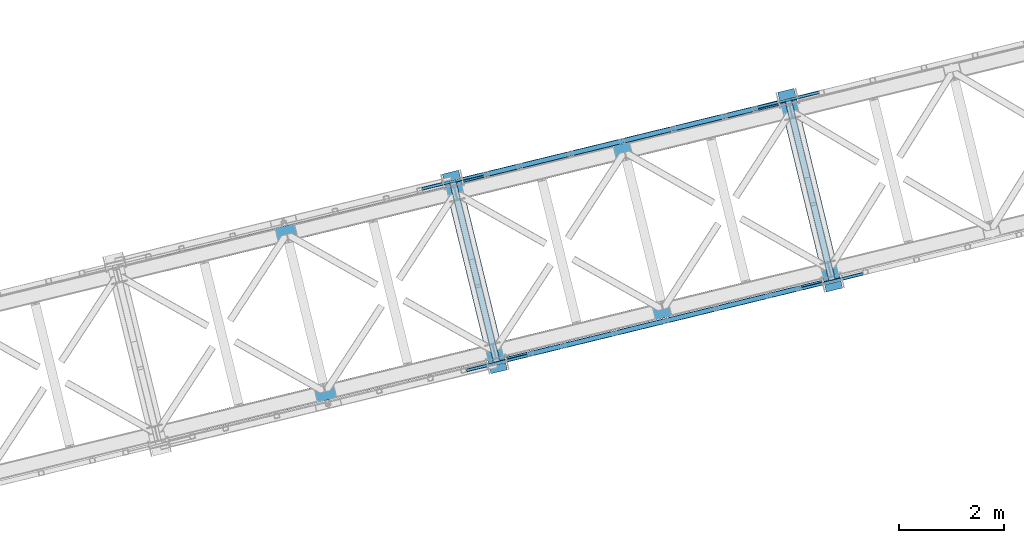
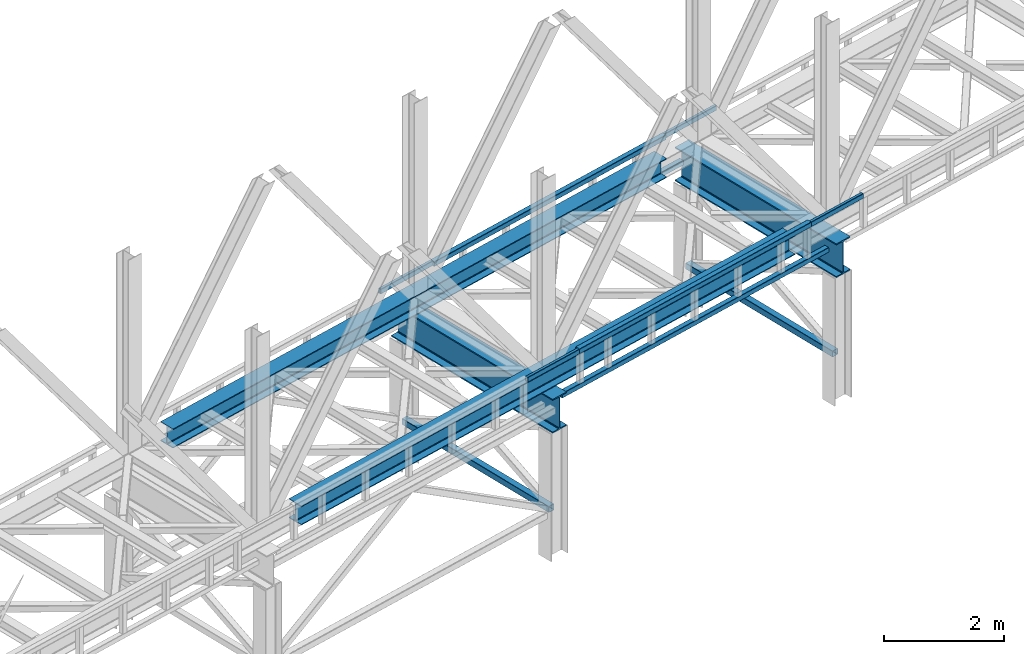
# One storey, part 17 of 93: 12 beams, 2 members.
"""IFC4 building model written with IfcOpenShell, lengths in millimetres."""

from ifc_helpers import new_model, entity, si_unit, converted_unit, derived_unit, direction, frame, origin, place, context, subcontext, project, spatial, indexed_curve, outline, extrude, material, type_object, element, save


model = new_model("IFC4")

# Units and contexts
model_context = context("Model", 3, precision=0.01, world=origin(), true_north=direction((6.12303176911189e-17, 1.0)))
plan_context = context("Plan", 3, precision=0.01, world=origin(), true_north=direction((6.12303176911189e-17, 1.0)))
body_context = subcontext(model_context, "Body", "Model", "MODEL_VIEW")
ifc_project = project(units=[si_unit("LENGTHUNIT", "METRE", prefix="MILLI"), si_unit("AREAUNIT", "SQUARE_METRE"), si_unit("VOLUMEUNIT", "CUBIC_METRE"), converted_unit("PLANEANGLEUNIT", "DEGREE", entity("IfcRatioMeasure", 0.0174532925199433), si_unit("PLANEANGLEUNIT", "RADIAN"), dimensions=[0, 0, 0, 0, 0, 0, 0]), si_unit("MASSUNIT", "GRAM", prefix="KILO"), derived_unit("MASSDENSITYUNIT", [(si_unit("MASSUNIT", "GRAM", prefix="KILO"), 1), (si_unit("LENGTHUNIT", "METRE"), -3)]), derived_unit("MOMENTOFINERTIAUNIT", [(si_unit("LENGTHUNIT", "METRE"), 4)]), si_unit("TIMEUNIT", "SECOND"), si_unit("FREQUENCYUNIT", "HERTZ"), si_unit("THERMODYNAMICTEMPERATUREUNIT", "DEGREE_CELSIUS"), derived_unit("THERMALTRANSMITTANCEUNIT", [(si_unit("MASSUNIT", "GRAM", prefix="KILO"), 1), (si_unit("THERMODYNAMICTEMPERATUREUNIT", "KELVIN"), -1), (si_unit("TIMEUNIT", "SECOND"), -3)]), derived_unit("VOLUMETRICFLOWRATEUNIT", [(si_unit("LENGTHUNIT", "METRE"), 3), (si_unit("TIMEUNIT", "SECOND"), -1)]), derived_unit("MASSFLOWRATEUNIT", [(si_unit("MASSUNIT", "GRAM", prefix="KILO"), 1), (si_unit("TIMEUNIT", "SECOND"), -1)]), derived_unit("ROTATIONALFREQUENCYUNIT", [(si_unit("TIMEUNIT", "SECOND"), -1)]), si_unit("ELECTRICCURRENTUNIT", "AMPERE"), si_unit("ELECTRICVOLTAGEUNIT", "VOLT"), si_unit("POWERUNIT", "WATT"), si_unit("FORCEUNIT", "NEWTON", prefix="KILO"), si_unit("ILLUMINANCEUNIT", "LUX"), si_unit("LUMINOUSFLUXUNIT", "LUMEN"), si_unit("LUMINOUSINTENSITYUNIT", "CANDELA"), derived_unit("USERDEFINED", [(si_unit("MASSUNIT", "GRAM", prefix="KILO"), -1), (si_unit("LENGTHUNIT", "METRE"), -2), (si_unit("TIMEUNIT", "SECOND"), 3), (si_unit("LUMINOUSFLUXUNIT", "LUMEN"), 1)]), derived_unit("LINEARVELOCITYUNIT", [(si_unit("LENGTHUNIT", "METRE"), 1), (si_unit("TIMEUNIT", "SECOND"), -1)]), si_unit("PRESSUREUNIT", "PASCAL"), derived_unit("USERDEFINED", [(si_unit("LENGTHUNIT", "METRE"), -2), (si_unit("MASSUNIT", "GRAM", prefix="KILO"), 1), (si_unit("TIMEUNIT", "SECOND"), -2)]), derived_unit("LINEARFORCEUNIT", [(si_unit("MASSUNIT", "GRAM", prefix="KILO"), 1), (si_unit("LENGTHUNIT", "METRE"), 1), (si_unit("TIMEUNIT", "SECOND"), -2), (si_unit("LENGTHUNIT", "METRE"), -1)]), derived_unit("PLANARFORCEUNIT", [(si_unit("MASSUNIT", "GRAM", prefix="KILO"), 1), (si_unit("LENGTHUNIT", "METRE"), 1), (si_unit("TIMEUNIT", "SECOND"), -2), (si_unit("LENGTHUNIT", "METRE"), -2)])], contexts=[model_context, plan_context])

# Site, building, storey
site_placement = place(None, origin())
site = spatial("IfcSite", under=ifc_project, at=site_placement, CompositionType="ELEMENT")
building_placement = place(site_placement, origin())
building = spatial("IfcBuilding", under=site, at=building_placement, CompositionType="ELEMENT")
storey_placement = place(building_placement, frame((0.0, 0.0, 15900.0)))
storey = spatial("IfcBuildingStorey", under=building, at=storey_placement, CompositionType="ELEMENT", Elevation=15900.0)

# Beams
ifc_material = material(Name="Metal painted (White)")
beam_type = type_object("IfcBeamType", PredefinedType="BEAM")
beam_1_placement = place(storey_placement, origin())
element("IfcBeam", 1, at=beam_1_placement, inside=storey, type_object=beam_type, material=ifc_material, ObjectType="Steel Beam", PredefinedType="BEAM", context=body_context, shape_type="SweptSolid", body=[
    extrude(outline(indexed_curve([(-345.500000000002, -159.999999999997), (-322.5, -159.999999999997), (-322.5, -37.4999999999995), (-320.216385975338, -26.019497029052), (-313.713203435595, -16.2867965644011), (-303.980502970953, -9.78361402465815), (-292.499999999998, -7.49999999999633), (292.500000000001, -7.49999999999633), (303.980502970953, -9.78361402465815), (313.713203435597, -16.2867965644011), (320.21638597534, -26.019497029052), (322.5, -37.4999999999995), (322.5, -159.999999999997), (345.499999999997, -159.999999999997), (345.499999999997, 159.999999999997), (322.5, 159.999999999997), (322.5, 37.4999999999995), (320.21638597534, 26.019497029052), (313.713203435597, 16.2867965644011), (303.980502970953, 9.78361402465815), (292.500000000001, 7.50000000000079), (-292.499999999998, 7.50000000000526), (-303.98050297095, 9.78361402466262), (-313.713203435591, 16.2867965644011), (-320.216385975338, 26.0194970290475), (-322.5, 37.4999999999995), (-322.5, 160.000000000002), (-345.500000000002, 159.999999999997), (-345.500000000002, -159.999999999997)], self_intersect=False)), frame((-35697.8015074168, 8488.14785129996, 2947.5), z_axis=(-0.236826092990338, 0.971552058141473, 0.0), x_axis=(0.0, 0.0, 1.0)), (0.0, 0.0, 1.0), 3899.99999999999),
])
beam_2_placement = place(storey_placement, origin())
element("IfcBeam", 2, at=beam_2_placement, inside=storey, type_object=beam_type, material=ifc_material, ObjectType="Steel Beam", PredefinedType="BEAM", context=body_context, shape_type="SweptSolid", body=[
    extrude(outline(indexed_curve([(-345.500000000002, -159.999999999992), (-322.5, -159.999999999992), (-322.5, -37.4999999999948), (-320.216385975338, -26.0194970290473), (-313.713203435595, -16.2867965643967), (-303.980502970953, -9.78361402465343), (-292.499999999998, -7.49999999999633), (292.500000000001, -7.49999999999633), (303.980502970953, -9.78361402465343), (313.713203435597, -16.2867965643967), (320.21638597534, -26.0194970290473), (322.5, -37.4999999999948), (322.5, -159.999999999992), (345.499999999997, -159.999999999992), (345.499999999997, 160.000000000006), (322.5, 160.000000000006), (322.5, 37.5000000000037), (320.21638597534, 26.0194970290562), (313.713203435597, 16.2867965644056), (303.980502970953, 9.78361402466287), (292.500000000001, 7.50000000000526), (-292.499999999998, 7.50000000000526), (-303.98050297095, 9.78361402466708), (-313.713203435591, 16.2867965644014), (-320.216385975338, 26.019497029052), (-322.5, 37.5000000000037), (-322.5, 160.000000000001), (-345.500000000002, 160.000000000006), (-345.500000000002, -159.999999999992)], self_intersect=False)), frame((-29334.1355265902, 10039.3587603867, 2947.5), z_axis=(-0.23682609299033, 0.971552058141475, 0.0), x_axis=(0.0, 0.0, 1.0)), (0.0, 0.0, 1.0), 3899.99999999999),
])
beam_3_placement = place(storey_placement, origin())
element("IfcBeam", 3, at=beam_3_placement, inside=storey, type_object=beam_type, material=ifc_material, ObjectType="Steel Beam", PredefinedType="BEAM", context=body_context, shape_type="SweptSolid", body=[
    extrude(outline(indexed_curve([(-195.999999999999, -150.000000000003), (-179.999999999996, -150.000000000003), (-179.999999999996, -27.7500000000041), (-178.325349715245, -19.3309644879692), (-173.556349186101, -12.1936508138986), (-166.419035512029, -7.42465028475491), (-157.999999999997, -5.7500000000032), (158.000000000005, -5.7500000000032), (166.419035512033, -7.42465028475491), (173.556349186107, -12.1936508138986), (178.325349715251, -19.3309644879692), (180.0, -27.7500000000041), (180.0, -150.000000000003), (196.000000000005, -150.000000000003), (196.000000000005, 149.999999999998), (180.0, 149.999999999998), (180.0, 27.7499999999978), (178.325349715251, 19.330964487965), (173.556349186107, 12.1936508138923), (166.419035512033, 7.42465028474965), (158.000000000005, 5.74999999999584), (-157.999999999997, 5.74999999999584), (-166.419035512029, 7.42465028474965), (-173.556349186101, 12.1936508138933), (-178.325349715245, 19.330964487965), (-179.999999999996, 27.7499999999978), (-179.999999999996, 150.0), (-195.999999999999, 149.999999999998), (-195.999999999999, -150.000000000003)], self_intersect=False)), frame((-41354.6674774729, 7520.93929218686, 3489.0), z_axis=(0.971552058141476, 0.236826092990324, 0.0), x_axis=(0.0, 0.0, 1.0)), (0.0, 0.0, 1.0), 11400.0),
])
beam_4_placement = place(storey_placement, origin())
element("IfcBeam", 4, at=beam_4_placement, inside=storey, type_object=beam_type, material=ifc_material, ObjectType="Steel Beam", PredefinedType="BEAM", context=body_context, shape_type="SweptSolid", body=[
    extrude(outline(indexed_curve([(-195.999999999999, -150.000000000002), (-179.999999999996, -150.000000000002), (-179.999999999996, -27.750000000002), (-178.325349715245, -19.3309644879681), (-173.556349186101, -12.1936508138975), (-166.419035512029, -7.42465028475491), (-157.999999999997, -5.75000000000215), (158.000000000005, -5.75000000000215), (166.419035512033, -7.42465028475491), (173.556349186107, -12.1936508138975), (178.325349715251, -19.3309644879681), (180.0, -27.750000000002), (180.0, -150.000000000002), (196.000000000005, -150.000000000002), (196.000000000005, 149.999999999998), (180.0, 149.999999999998), (180.0, 27.7499999999978), (178.325349715251, 19.330964487966), (173.556349186107, 12.1936508138933), (166.419035512033, 7.4246502847507), (158.000000000005, 5.74999999999794), (-157.999999999997, 5.74999999999794), (-166.419035512029, 7.4246502847486), (-173.556349186101, 12.1936508138912), (-178.325349715247, 19.330964487966), (-179.999999999996, 27.7499999999957), (-179.999999999996, 149.999999999998), (-195.999999999999, 149.999999999998), (-195.999999999999, -150.000000000002)], self_intersect=False)), frame((-42088.828365743, 10532.7506724254, 3489.0), z_axis=(0.971552058141477, 0.236826092990322, 0.0), x_axis=(0.0, 0.0, 1.0)), (0.0, 0.0, 1.0), 11400.0),
])
beam_5_placement = place(storey_placement, origin())
element("IfcBeam", 5, at=beam_5_placement, inside=storey, type_object=beam_type, material=ifc_material, ObjectType="Steel Beam", PredefinedType="BEAM", context=body_context, shape_type="SweptSolid", body=[
    extrude(outline(indexed_curve([(29.4768951152948, -56.8428769008151), (33.3787015556177, -56.8428769008151), (36.9835006656516, -55.3497202198128), (39.7424944584837, -52.5907264269822), (41.2356511394923, -48.9859273169492), (56.8428769008144, 29.4768951153021), (56.8428769008163, 33.3787015556236), (55.3497202198083, 36.983500665662), (52.5907264269817, 39.7424944584911), (48.9859273169474, 41.2356511394989), (-29.4768951153043, 56.8428769008214), (-33.3787015556268, 56.8428769008235), (-36.9835006656611, 55.3497202198191), (-39.7424944584921, 52.5907264269883), (-41.2356511395007, 48.9859273169553), (-56.8428769008228, -29.476895115296), (-56.8428769008247, -33.3787015556175), (-55.3497202198188, -36.9835006656555), (-52.5907264269907, -39.7424944584827), (-48.9859273169579, -41.2356511394924), (29.4768951152948, -56.8428769008151)], self_intersect=False), holes=[indexed_curve([(-50.9634988887243, -25.5484203233641), (-37.307176347567, 43.1065493048579), (-35.8140196665605, 46.7113484148914), (-33.0550258737274, 49.4703422077217), (-29.450226763691, 50.9634988887257), (-25.5484203233706, 50.963498888724), (43.106549304852, 37.3071763475664), (46.7113484148832, 35.8140196665592), (49.4703422077129, 33.0550258737295), (50.9634988887188, 29.4502267636915), (50.9634988887169, 25.54842032337), (37.3071763475586, -43.1065493048518), (35.81401966655, -46.7113484148849), (33.0550258737224, -49.4703422077141), (29.4502267636851, -50.9634988887179), (25.5484203233636, -50.963498888716), (-43.1065493048565, -37.3071763475567), (-46.7113484148907, -35.8140196665489), (-49.4703422077195, -33.0550258737194), (-50.9634988887242, -29.450226763686), (-50.9634988887243, -25.5484203233641)], self_intersect=False)]), frame((-36379.7476398528, 12130.2556850215, 3118.0), z_axis=(0.971552058141621, 0.236826092989728, 0.0), x_axis=(-0.232275546019818, 0.952883957770662, 0.195090322016531)), (0.0, 0.0, 1.0), 6149.99999999998),
])
beam_6_placement = place(storey_placement, origin())
element("IfcBeam", 6, at=beam_6_placement, inside=storey, type_object=beam_type, material=ifc_material, ObjectType="Steel Beam", PredefinedType="BEAM", context=body_context, shape_type="SweptSolid", body=[
    extrude(outline(indexed_curve([(29.4768951153914, -56.8428769007589), (33.378701555713, -56.8428769007589), (36.9835006657449, -55.3497202197486), (39.742494458576, -52.590726426912), (41.2356511395787, -48.9859273168765), (56.8428769007726, 29.4768951154003), (56.8428769007651, 33.3787015557224), (55.3497202197521, 36.9835006657516), (52.5907264269217, 39.7424944585804), (48.985927316883, 41.2356511395828), (-29.4768951153921, 56.8428769007767), (-33.3787015557146, 56.8428769007724), (-36.9835006657473, 55.3497202197579), (-39.7424944585747, 52.5907264269294), (-41.2356511395774, 48.9859273168939), (-56.8428769007734, -29.4768951153824), (-56.8428769007669, -33.3787015557044), (-55.3497202197555, -36.9835006657421), (-52.5907264269213, -39.7424944585673), (-48.9859273168837, -41.235651139565), (29.4768951153914, -56.8428769007589)], self_intersect=False), holes=[indexed_curve([(-50.9634988886772, -25.5484203234418), (-37.307176347632, 43.1065493048025), (-35.8140196666283, 46.7113484148378), (-33.055025873804, 49.4703422076669), (-29.4502267637722, 50.9634988886772), (-25.5484203234488, 50.9634988886857), (43.106549304796, 37.3071763476402), (46.7113484148319, 35.8140196666341), (49.470342207663, 33.0550258738095), (50.9634988886741, 29.4502267637807), (50.9634988886805, 25.5484203234587), (37.3071763476354, -43.1065493047855), (35.8140196666347, -46.7113484148214), (33.0550258738057, -49.4703422076584), (29.4502267637739, -50.9634988886687), (25.5484203234514, -50.963498888673), (-43.1065493047935, -37.3071763476275), (-46.7113484148281, -35.814019666626), (-49.4703422076613, -33.055025873801), (-50.9634988886727, -29.4502267637633), (-50.9634988886772, -25.5484203234418)], self_intersect=False)]), frame((-35991.1268165962, 12224.9861222176, 3830.0), z_axis=(0.971552058141621, 0.236826092989728, 0.0), x_axis=(0.232275546019893, -0.952883957770972, -0.19509032201493)), (0.0, 0.0, 1.0), 5349.99999999999),
])
beam_7_placement = place(storey_placement, origin())
element("IfcBeam", 7, at=beam_7_placement, inside=storey, type_object=beam_type, material=ifc_material, ObjectType="Steel Beam", PredefinedType="BEAM", context=body_context, shape_type="SweptSolid", body=[
    extrude(outline(indexed_curve([(9.86118950714821, -52.94107046051), (13.7629959474724, -52.94107046051), (17.3677950575093, -51.4479137795159), (20.1267888503473, -48.6889199866879), (21.6199455313576, -45.0841208766564), (37.2271712928086, 33.3787015555692), (37.2271712928189, 37.2805079958903), (35.7340146118184, 40.8853071059286), (32.9750208189941, 43.6443008987626), (29.3702217089642, 45.1374575797804), (-9.86118950715112, 52.9410704605061), (-13.7629959474724, 52.94107046051), (-17.3677950575122, 51.447913779512), (-20.1267888503473, 48.6889199866879), (-21.6199455313597, 45.0841208766568), (-37.2271712928107, -33.3787015555687), (-37.2271712928189, -37.2805079958903), (-35.7340146118213, -40.8853071059325), (-32.9750208189941, -43.6443008987626), (-29.370221708965, -45.1374575797846), (9.86118950714821, -52.94107046051)], self_intersect=False), holes=[indexed_curve([(-31.3477932807058, -29.4502267636464), (-17.6914707394355, 39.204742864553), (-16.1983140584179, 42.8095419745831), (-13.439320265588, 45.5685357674083), (-9.83452115555026, 47.0616924484066), (-5.9327147152257, 47.0616924483977), (23.4908436968584, 41.2089827878538), (27.0956428068893, 39.7158261068403), (29.8546365997166, 36.9568323140057), (31.3477932807141, 33.3520332039679), (31.3477932807058, 29.4502267636464), (17.6914707394355, -39.204742864553), (16.1983140584221, -42.8095419745839), (13.4393202655851, -45.5685357674121), (9.83452115554819, -47.0616924484062), (5.93271471522983, -47.0616924483985), (-23.4908436968584, -41.2089827878538), (-27.0956428068893, -39.7158261068403), (-29.8546365997094, -36.9568323140071), (-31.3477932807141, -33.3520332039679), (-31.3477932807058, -29.4502267636464)], self_intersect=False)]), frame((-37161.7258082258, 11960.225851792, 3830.0), z_axis=(0.971552058141752, 0.236826092989194, 0.0), x_axis=(-0.232275546019742, 0.952883957770353, 0.195090322018133)), (0.0, 0.0, 1.0), 1199.99999999998),
])
beam_8_placement = place(storey_placement, origin())
element("IfcBeam", 8, at=beam_8_placement, inside=storey, type_object=beam_type, material=ifc_material, ObjectType="Steel Beam", PredefinedType="BEAM", context=body_context, shape_type="SweptSolid", body=[
    extrude(outline(indexed_curve([(9.86118950714344, -52.9410704605112), (13.7629959474656, -52.9410704605112), (17.3677950575047, -51.4479137795179), (20.1267888503399, -48.6889199866896), (21.6199455313537, -45.0841208766589), (37.2271712928143, 33.3787015555648), (37.227171292823, 37.2805079958863), (35.7340146118239, 40.8853071059246), (32.9750208189968, 43.6443008987596), (29.3702217089691, 45.1374575797773), (-9.86118950714429, 52.9410704605069), (-13.7629959474676, 52.9410704605116), (-17.3677950575055, 51.4479137795136), (-20.1267888503399, 48.6889199866896), (-21.6199455313537, 45.0841208766589), (-37.2271712928143, -33.3787015555648), (-37.2271712928209, -37.2805079958867), (-35.7340146118227, -40.8853071059293), (-32.9750208189989, -43.6443008987591), (-29.3702217089699, -45.1374575797815), (9.86118950714344, -52.9410704605112)], self_intersect=False), holes=[indexed_curve([(-31.3477932807069, -29.4502267636435), (-17.6914707394291, 39.2047428645544), (-16.1983140584143, 42.8095419745849), (-13.439320265582, 45.5685357674094), (-9.83452115554203, 47.061692448407), (-5.9327147152216, 47.0616924483985), (23.4908436968629, 41.2089827878513), (27.0956428068946, 39.7158261068372), (29.8546365997175, 36.9568323140031), (31.3477932807197, 33.3520332039642), (31.3477932807111, 29.4502267636427), (17.6914707394333, -39.2047428645553), (16.1983140584184, -42.8095419745858), (13.4393202655811, -45.5685357674137), (9.83452115554409, -47.0616924484074), (5.93271471522366, -47.0616924483989), (-23.4908436968609, -41.2089827878517), (-27.0956428068895, -39.7158261068383), (-29.8546365997142, -36.9568323140082), (-31.3477932807156, -33.352033203965), (-31.3477932807069, -29.4502267636435)], self_intersect=False)]), frame((-30796.9941099807, 13507.0647766171, 3830.0), z_axis=(0.971552058141691, 0.236826092989445, 0.0), x_axis=(-0.232275546019865, 0.952883957770302, 0.195090322018236)), (0.0, 0.0, 1.0), 1200.00000000001),
])
beam_9_placement = place(storey_placement, origin())
element("IfcBeam", 9, at=beam_9_placement, inside=storey, type_object=beam_type, material=ifc_material, ObjectType="Steel Beam", PredefinedType="BEAM", context=body_context, shape_type="SweptSolid", body=[
    extrude(outline(indexed_curve([(29.4768951153284, -56.8428769008039), (33.3787015556499, -56.8428769008039), (36.9835006656849, -55.3497202197958), (39.7424944585137, -52.5907264269679), (41.2356511395206, -48.9859273169341), (56.8428769008042, 29.4768951153248), (56.8428769008037, 33.3787015556486), (55.349720219797, 36.9835006656857), (52.5907264269665, 39.7424944585117), (48.9859273169325, 41.2356511395176), (-29.4768951153288, 56.8428769008018), (-33.3787015556503, 56.8428769008018), (-36.9835006656844, 55.3497202197979), (-39.7424944585142, 52.5907264269658), (-41.2356511395214, 48.9859273169299), (-56.8428769008051, -29.476895115329), (-56.8428769008041, -33.3787015556507), (-55.3497202197966, -36.9835006656836), (-52.5907264269669, -39.7424944585138), (-48.985927316933, -41.2356511395197), (29.4768951153284, -56.8428769008039)], self_intersect=False), holes=[indexed_curve([(-50.9634988887085, -25.5484203233942), (-37.3071763475859, 43.1065493048346), (-35.8140196665801, 46.7113484148686), (-33.0550258737493, 49.4703422077006), (-29.4502267637143, 50.9634988887087), (-25.5484203233908, 50.9634988887083), (43.1065493048363, 37.3071763475849), (46.7113484148724, 35.8140196665786), (49.470342207701, 33.0550258737486), (50.9634988887077, 29.4502267637115), (50.9634988887076, 25.54842032339), (37.307176347583, -43.1065493048385), (35.8140196665761, -46.7113484148723), (33.0550258737489, -49.4703422077027), (29.4502267637147, -50.9634988887066), (25.5484203233923, -50.9634988887064), (-43.1065493048349, -37.307176347583), (-46.7113484148709, -35.8140196665767), (-49.4703422076989, -33.055025873749), (-50.9634988887075, -29.4502267637159), (-50.9634988887085, -25.5484203233942)], self_intersect=False)]), frame((-35548.7248795497, 8721.07951300305, 3118.0), z_axis=(0.971552058141591, 0.236826092989854, 0.0), x_axis=(-0.232275546019904, 0.95288395777074, 0.195090322016049)), (0.0, 0.0, 1.0), 6149.99999999998),
])
beam_10_placement = place(storey_placement, origin())
element("IfcBeam", 10, at=beam_10_placement, inside=storey, type_object=beam_type, material=ifc_material, ObjectType="Steel Beam", PredefinedType="BEAM", context=body_context, shape_type="SweptSolid", body=[
    extrude(outline(indexed_curve([(29.4768951153914, -56.842876900761), (33.378701555712, -56.842876900761), (36.983500665745, -55.3497202197511), (39.7424944585721, -52.5907264269138), (41.235651139575, -48.9859273168784), (56.8428769007732, 29.4768951153975), (56.842876900768, 33.3787015557192), (55.3497202197561, 36.9835006657483), (52.5907264269239, 39.7424944585777), (48.9859273168883, 41.2356511395796), (-29.476895115389, 56.8428769007782), (-33.3787015557115, 56.8428769007741), (-36.9835006657453, 55.34972021976), (-39.7424944585708, 52.5907264269312), (-41.2356511395737, 48.9859273168958), (-56.8428769007719, -29.4768951153801), (-56.8428769007667, -33.3787015557018), (-55.3497202197565, -36.9835006657394), (-52.5907264269234, -39.7424944585645), (-48.9859273168859, -41.2356511395624), (29.4768951153914, -56.842876900761)], self_intersect=False), holes=[indexed_curve([(-50.9634988886785, -25.5484203234391), (-37.3071763476287, 43.1065493048042), (-35.8140196666226, 46.711348414839), (-33.0550258738003, 49.4703422076684), (-29.4502267637694, 50.9634988886787), (-25.548420323445, 50.9634988886868), (43.106549304797, 37.3071763476382), (46.7113484148338, 35.8140196666316), (49.4703422076658, 33.0550258738067), (50.9634988886777, 29.4502267637776), (50.9634988886819, 25.5484203234561), (37.3071763476341, -43.1065493047876), (35.8140196666342, -46.7113484148237), (33.055025873803, -49.4703422076601), (29.4502267637711, -50.9634988886702), (25.5484203234486, -50.9634988886743), (-43.1065493047934, -37.3071763476257), (-46.711348414829, -35.8140196666237), (-49.4703422076652, -33.055025873798), (-50.9634988886733, -29.4502267637608), (-50.9634988886785, -25.5484203234391)], self_intersect=False)]), frame((-35160.1040562931, 8815.80995019918, 3830.0), z_axis=(0.971552058141591, 0.236826092989854, 0.0), x_axis=(0.232275546019955, -0.952883957770947, -0.195090322014981)), (0.0, 0.0, 1.0), 5349.99999999999),
])
beam_11_placement = place(storey_placement, origin())
element("IfcBeam", 11, at=beam_11_placement, inside=storey, type_object=beam_type, material=ifc_material, ObjectType="Steel Beam", PredefinedType="BEAM", context=body_context, shape_type="SweptSolid", body=[
    extrude(outline(indexed_curve([(9.86118950714636, -52.9410704605107), (13.7629959474695, -52.9410704605107), (17.3677950575075, -51.447913779517), (20.1267888503426, -48.6889199866885), (21.6199455313572, -45.0841208766579), (37.2271712928125, 33.3787015555668), (37.2271712928199, 37.2805079958885), (35.7340146118217, 40.8853071059265), (32.9750208189965, 43.6443008987609), (29.3702217089666, 45.1374575797788), (-9.8611895071472, 52.9410704605064), (-13.7629959474695, 52.9410704605107), (-17.3677950575084, 51.4479137795127), (-20.1267888503426, 48.6889199866885), (-21.6199455313572, 45.0841208766579), (-37.2271712928125, -33.3787015555668), (-37.2271712928199, -37.2805079958885), (-35.7340146118225, -40.8853071059308), (-32.9750208189965, -43.6443008987609), (-29.3702217089675, -45.1374575797831), (9.86118950714636, -52.9410704605107)], self_intersect=False), holes=[indexed_curve([(-31.3477932807053, -29.4502267636452), (-17.6914707394323, 39.2047428645537), (-16.1983140584177, 42.8095419745843), (-13.4393202655865, 45.5685357674091), (-9.83452115554665, 47.0616924484069), (-5.93271471522212, 47.0616924483978), (23.4908436968607, 41.2089827878526), (27.0956428068914, 39.7158261068389), (29.8546365997166, 36.9568323140045), (31.3477932807159, 33.3520332039663), (31.3477932807084, 29.4502267636446), (17.6914707394344, -39.2047428645542), (16.1983140584197, -42.8095419745847), (13.4393202655846, -45.5685357674132), (9.83452115554871, -47.0616924484073), (5.93271471522725, -47.0616924483988), (-23.4908436968597, -41.2089827878528), (-27.0956428068894, -39.7158261068393), (-29.8546365997112, -36.95683231401), (-31.3477932807138, -33.3520332039667), (-31.3477932807053, -29.4502267636452)], self_intersect=False)]), frame((-36321.2300042031, 8512.18759744794, 3830.0), z_axis=(0.971552058141721, 0.236826092989319, 0.0), x_axis=(-0.232275546019804, 0.952883957770327, 0.195090322018185)), (0.0, 0.0, 1.0), 1199.99999999998),
])
beam_12_placement = place(storey_placement, origin())
element("IfcBeam", 12, at=beam_12_placement, inside=storey, type_object=beam_type, material=ifc_material, ObjectType="Steel Beam", PredefinedType="BEAM", context=body_context, shape_type="SweptSolid", body=[
    extrude(outline(indexed_curve([(9.86118950714821, -52.94107046051), (13.7629959474724, -52.94107046051), (17.3677950575093, -51.4479137795159), (20.1267888503473, -48.6889199866879), (21.6199455313597, -45.0841208766568), (37.2271712928107, 33.3787015555687), (37.2271712928189, 37.2805079958903), (35.7340146118184, 40.8853071059286), (32.9750208189941, 43.6443008987626), (29.3702217089642, 45.1374575797804), (-9.86118950714905, 52.9410704605057), (-13.7629959474724, 52.94107046051), (-17.3677950575101, 51.4479137795116), (-20.1267888503473, 48.6889199866879), (-21.6199455313597, 45.0841208766568), (-37.2271712928107, -33.3787015555687), (-37.2271712928189, -37.2805079958903), (-35.7340146118193, -40.8853071059329), (-32.9750208189941, -43.6443008987626), (-29.370221708965, -45.1374575797846), (9.86118950714821, -52.94107046051)], self_intersect=False), holes=[indexed_curve([(-31.3477932807017, -29.4502267636472), (-17.6914707394334, 39.2047428645526), (-16.1983140584179, 42.8095419745831), (-13.439320265588, 45.5685357674083), (-9.83452115555026, 47.0616924484066), (-5.93271471522776, 47.0616924483981), (23.4908436968584, 41.2089827878538), (27.0956428068893, 39.7158261068403), (29.8546365997135, 36.9568323140063), (31.3477932807161, 33.3520332039675), (31.3477932807079, 29.450226763646), (17.6914707394396, -39.2047428645539), (16.1983140584221, -42.8095419745839), (13.4393202655851, -45.5685357674121), (9.83452115555026, -47.0616924484066), (5.93271471522776, -47.0616924483981), (-23.4908436968584, -41.2089827878538), (-27.0956428068872, -39.7158261068407), (-29.8546365997103, -36.9568323140114), (-31.3477932807099, -33.3520332039688), (-31.3477932807017, -29.4502267636472)], self_intersect=False)]), frame((-29957.5640233765, 10063.3985065347, 3830.0), z_axis=(0.971552058141752, 0.236826092989194, 0.0), x_axis=(-0.232275546019742, 0.952883957770353, 0.195090322018133)), (0.0, 0.0, 1.0), 1200.00000000001),
])

# Members
member_type_1 = type_object("IfcMemberType", PredefinedType="BRACE")
member_1_placement = place(storey_placement, origin())
element("IfcMember", 13, at=member_1_placement, inside=storey, type_object=member_type_1, ObjectType="Steel Vertical Brace", PredefinedType="BRACE", context=body_context, shape_type="SweptSolid", body=[
    extrude(outline(indexed_curve([(41.2596526560083, -71.9315025750552), (44.3810978082601, -71.9315025750552), (47.2649370962886, -70.7369772302474), (49.4721321305551, -68.5297821959818), (50.6666574753592, -65.6459429079524), (71.9315025750527, 41.2596526560115), (71.931502575051, 44.3810978082705), (70.736977230239, 47.2649370962958), (68.5297821959735, 49.4721321305612), (65.6459429079506, 50.666657475363), (-41.2596526560082, 71.9315025750574), (-44.3810978082732, 71.9315025750578), (-47.2649370962978, 70.7369772302471), (-49.4721321305635, 68.5297821959857), (-50.6666574753676, 65.6459429079563), (-71.9315025750654, -41.2596526560068), (-71.931502575059, -44.3810978082667), (-70.7369772302526, -47.2649370962953), (-68.5297821959911, -49.4721321305577), (-65.6459429079545, -50.66665747536), (41.2596526560083, -71.9315025750552)], self_intersect=False), holes=[indexed_curve([(-67.2280001653862, -38.1168728224595), (-47.523877641812, 60.9424404982808), (-46.3293522970123, 63.826279786311), (-44.1221572627466, 66.0334748205724), (-41.2383179747225, 67.228000165381), (-38.1168728224609, 67.2280001653834), (60.942440498271, 47.5238776418136), (63.8262797863027, 46.32935229701), (66.0334748205641, 44.1221572627454), (67.2280001653714, 41.2383179747211), (67.2280001653731, 38.1168728224621), (47.5238776418037, -60.9424404982769), (46.329352297, -63.8262797863042), (44.1221572627374, -66.0334748205728), (41.2383179747098, -67.2280001653762), (38.1168728224528, -67.2280001653796), (-60.9424404982837, -47.5238776418089), (-63.8262797863146, -46.3293522970011), (-66.0334748205817, -44.1221572627441), (-67.2280001653882, -41.2383179747156), (-67.2280001653862, -38.1168728224595)], self_intersect=False)]), frame((-35744.7988743251, 8680.94919329052, 898.0), z_axis=(-0.236826092990371, 0.971552058141465, 0.0), x_axis=(-0.952883957770726, -0.232275546020376, 0.195090322015555)), (0.0, 0.0, 1.0), 3545.80325659093),
])
member_type_2 = type_object("IfcMemberType", PredefinedType="BRACE")
member_2_placement = place(storey_placement, origin())
element("IfcMember", 14, at=member_2_placement, inside=storey, type_object=member_type_2, ObjectType="Steel Vertical Brace", PredefinedType="BRACE", context=body_context, shape_type="SweptSolid", body=[
    extrude(outline(indexed_curve([(41.2596526560248, -71.9315025750429), (44.3810978082809, -71.931502575043), (47.2649370963047, -70.7369772302335), (49.4721321305662, -68.5297821959665), (50.6666574753739, -65.6459429079376), (71.931502575041, 41.2596526560316), (71.9315025750339, 44.3810978082915), (70.7369772302253, 47.2649370963156), (68.5297821959636, 49.4721321305796), (65.6459429079359, 50.6666574753814), (-41.2596526560373, 71.9315025750476), (-44.3810978082938, 71.9315025750455), (-47.264937096318, 70.736977230234), (-49.4721321305833, 68.5297821959721), (-50.6666574753864, 65.6459429079423), (-71.9315025750493, -41.2596526560278), (-71.9315025750464, -44.3810978082868), (-70.736977230235, -47.2649370963159), (-68.5297821959724, -49.4721321305778), (-65.6459429079443, -50.6666574753776), (41.2596526560248, -71.9315025750429)], self_intersect=False), holes=[indexed_curve([(-67.2280001653793, -38.1168728224753), (-47.5238776418337, 60.9424404982684), (-46.3293522970306, 63.8262797862982), (-44.1221572627654, 66.0334748205624), (-41.238317974742, 67.2280001653697), (-38.116872822485, 67.2280001653739), (60.9424404982572, 47.5238776418307), (63.8262797862928, 46.3293522970228), (66.0334748205563, 44.1221572627651), (67.228000165364, 41.238317974739), (67.2280001653664, 38.1168728224801), (47.5238776418258, -60.9424404982647), (46.329352297014, -63.8262797862927), (44.1221572627529, -66.0334748205577), (41.2383179747296, -67.228000165365), (38.1168728224679, -67.2280001653683), (-60.9424404982702, -47.5238776418259), (-63.8262797863015, -46.3293522970211), (-66.0334748205608, -44.1221572627665), (-67.2280001653764, -41.2383179747344), (-67.2280001653793, -38.1168728224753)], self_intersect=False)]), frame((-29381.1328934984, 10232.1601023772, 898.0), z_axis=(-0.236826092990387, 0.971552058141461, 0.0), x_axis=(-0.952883957770777, -0.232275546020397, 0.195090322015281)), (0.0, 0.0, 1.0), 3545.80325659093),
])

save(model, "model.ifc")
